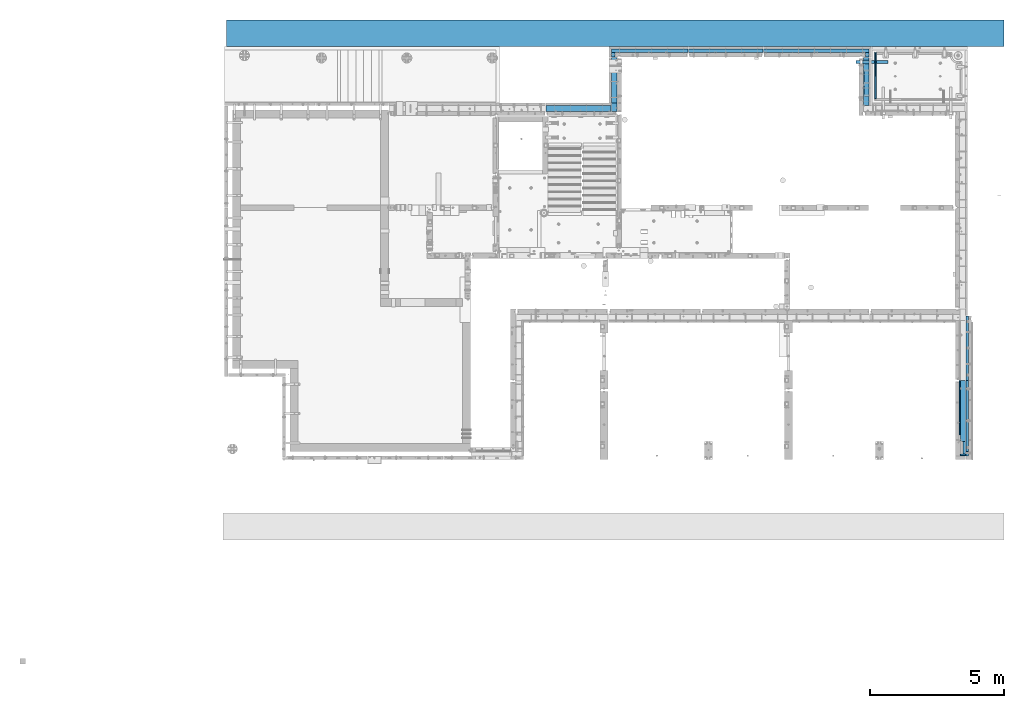
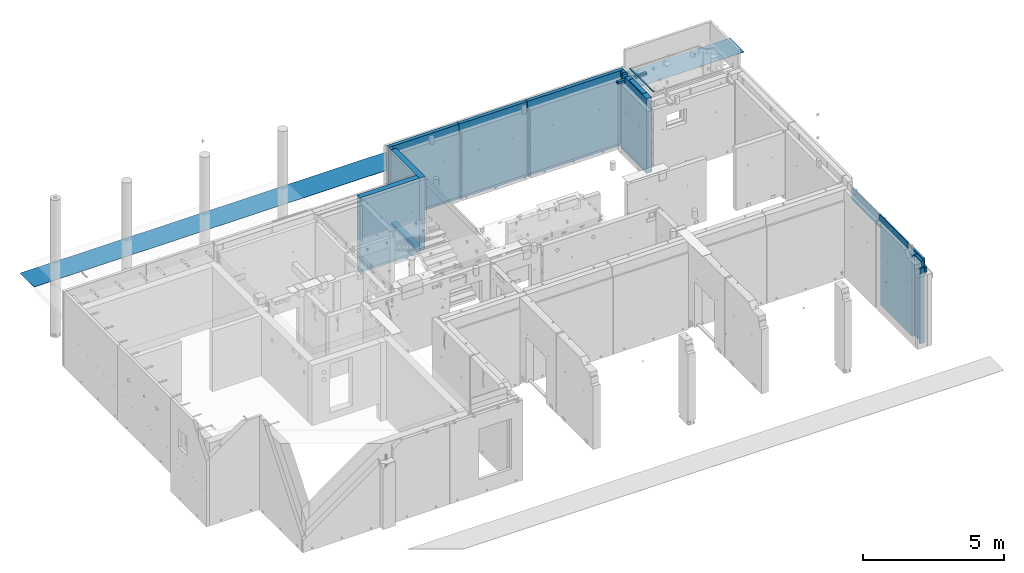
# One storey, part 82 of 264: 24 beams, 22 elements without a shape of their own.
"""IFC2X3 building model written with IfcOpenShell, lengths in millimetres."""

from ifc_helpers import new_model, si_unit, frame, origin_with_axes, place, context, subcontext, project, spatial, faceted_brep, material, type_object, element, aggregate, save


model = new_model("IFC2X3")

# Units and contexts
model_context = context("Model", 3, precision=1e-05, world=origin_with_axes())
body_context = subcontext(model_context, "Body", "Model", "MODEL_VIEW")
ifc_project = project(units=[si_unit("LENGTHUNIT", "METRE", prefix="MILLI"), si_unit("AREAUNIT", "SQUARE_METRE"), si_unit("VOLUMEUNIT", "CUBIC_METRE"), si_unit("MASSUNIT", "GRAM", prefix="KILO"), si_unit("TIMEUNIT", "SECOND"), si_unit("PLANEANGLEUNIT", "RADIAN"), si_unit("SOLIDANGLEUNIT", "STERADIAN"), si_unit("THERMODYNAMICTEMPERATUREUNIT", "DEGREE_CELSIUS"), si_unit("LUMINOUSINTENSITYUNIT", "LUMEN")], contexts=[model_context])

# Site, building, storey
site_placement = place(None, origin_with_axes())
site = spatial("IfcSite", under=ifc_project, at=site_placement, CompositionType="ELEMENT")
building_placement = place(site_placement, origin_with_axes())
building = spatial("IfcBuilding", under=site, at=building_placement, CompositionType="ELEMENT")
storey_placement = place(building_placement, origin_with_axes())
storey = spatial("IfcBuildingStorey", under=building, at=storey_placement, Name="K", CompositionType="ELEMENT", Elevation=0.0)

# Assemblies, beams
assembly_1_placement = place(storey_placement, origin_with_axes())
assembly_1 = element("IfcElementAssembly", 1, at=assembly_1_placement, inside=storey, AssemblyPlace="NOTDEFINED", PredefinedType="REINFORCEMENT_UNIT")
assembly_2_placement = place(assembly_1_placement, origin_with_axes())
assembly_2 = element("IfcElementAssembly", 2, at=assembly_2_placement, AssemblyPlace="NOTDEFINED", PredefinedType="NOTDEFINED")
ifc_material_1 = material(Name="Undefined/350")
beam_type_1 = type_object("IfcBeamType", Name="100X100X5", PredefinedType="NOTDEFINED")
beam_1_placement = place(assembly_2_placement, frame((32380.0034426031, 22424.9998567989, 81555.0), z_axis=(0.0, 0.0, 1.0), x_axis=(-0.999999999752625, 2.22429999942101e-05, 0.0)))
beam_1 = element("IfcBeam", 3, at=beam_1_placement, type_object=beam_type_1, material=ifc_material_1, ObjectType="100X100X5", context=body_context, shape_type="Brep", body=[
    faceted_brep([(1139.17579440585, -49.9744051074349, 6.25), (1139.1757927444, -44.9999999999991, 6.25), (1143.75111029171, -44.9999999999991, 10.8253175473074), (1143.75111195316, -49.9744035792783, 10.8253175473074), (1150.00111029171, -44.9999999999991, 12.5), (1150.00111195316, -49.9744014917787, 12.5), (1156.25111029171, -44.9999999999991, 10.8253175473074), (1156.25111195316, -49.9743994042774, 10.8253175473074), (1160.82642783901, -44.9999999999991, 6.25), (1160.82642950046, -49.9743978761207, 6.25), (1162.50111029171, -44.9999999999991, 0.0), (1162.50111195316, -49.9743973167779, 0.0), (1160.82642783901, -44.9999999999991, -6.25), (1160.82642950046, -49.9743978761207, -6.25), (1156.25111029171, -44.9999999999991, -10.8253175473074), (1156.25111195316, -49.9743994042774, -10.8253175473074), (1150.00111029171, -44.9999999999991, -12.5), (1150.00111195316, -49.9744014917787, -12.5), (1143.75111029171, -44.9999999999991, -10.8253175473074), (1143.75111195316, -49.9744035792783, -10.8253175473074), (1139.1757927444, -44.9999999999991, -6.25), (1139.17579440585, -49.9744051074349, -6.25), (1137.50111029171, -44.9999999999991, 0.0), (1137.50111195316, -49.9744056667778, 0.0), (1139.1757626844, 44.9999999999982, 6.25), (1139.17576100585, 50.0255948914664, 6.25), (1143.75107855316, 50.0255964196231, 10.8253175473074), (1143.75108023171, 44.9999999999982, 10.8253175473074), (1150.00107855316, 50.0255985071226, 12.5), (1150.00108023171, 44.9999999999982, 12.5), (1156.25107855315, 50.0256005946221, 10.8253175473074), (1156.2510802317, 44.9999999999982, 10.8253175473074), (1160.82639610046, 50.0256021227788, 6.25), (1160.82639777901, 44.9999999999982, 6.25), (1162.50107855316, 50.0256026821226, 0.0), (1162.50108023171, 44.9999999999982, 0.0), (1160.82639610046, 50.0256021227788, -6.25), (1160.82639777901, 44.9999999999982, -6.25), (1156.25107855315, 50.0256005946221, -10.8253175473074), (1156.2510802317, 44.9999999999982, -10.8253175473074), (1150.00107855316, 50.0255985071226, -12.5), (1150.00108023171, 44.9999999999982, -12.5), (1143.75107855316, 50.0255964196231, -10.8253175473074), (1143.75108023171, 44.9999999999982, -10.8253175473074), (1139.17576100585, 50.0255948914664, -6.25), (1139.1757626844, 44.9999999999982, -6.25), (1137.50107855316, 50.0255943321226, 0.0), (1137.5010802317, 44.9999999999982, 0.0), (1.81898940354586e-12, -50.0000000000009, -50.0), (1.81898940354586e-12, 49.9999999999991, -50.0), (1200.00449189278, 49.9999999999982, -50.0), (1200.00449189278, -50.0000000000009, -50.0), (1.81898940354586e-12, -50.0000000000009, 50.0), (1200.00449189278, -50.0000000000009, 50.0), (1.81898940354586e-12, 49.9999999999991, 50.0), (1200.00449189278, 49.9999999999982, 50.0), (0.0, 44.9999999999991, 45.0), (1.81898940354586e-12, -45.0000000000009, 45.0), (1.81898940354586e-12, -45.0000000000009, -45.0), (0.0, 44.9999999999991, -45.0), (1200.00449189278, 44.9999999999982, -45.0), (1200.00449189278, 44.9999999999982, 45.0), (1200.00449189278, -45.0000000000009, 45.0), (1200.00449189278, -45.0000000000009, -45.0)], [[[0, 1, 2, 3]], [[3, 2, 4, 5]], [[5, 4, 6, 7]], [[7, 6, 8, 9]], [[9, 8, 10, 11]], [[11, 10, 12, 13]], [[13, 12, 14, 15]], [[15, 14, 16, 17]], [[17, 16, 18, 19]], [[19, 18, 20, 21]], [[21, 20, 22, 23]], [[23, 22, 1, 0]], [[24, 25, 26, 27]], [[27, 26, 28, 29]], [[29, 28, 30, 31]], [[31, 30, 32, 33]], [[33, 32, 34, 35]], [[35, 34, 36, 37]], [[37, 36, 38, 39]], [[39, 38, 40, 41]], [[41, 40, 42, 43]], [[43, 42, 44, 45]], [[45, 44, 46, 47]], [[47, 46, 25, 24]], [[48, 49, 50, 51]], [[52, 48, 51, 53], [15, 17, 19, 21, 23, 0, 3, 5, 7, 9, 11, 13]], [[54, 52, 53, 55]], [[48, 52, 54, 49], [56, 57, 58, 59]], [[56, 59, 60, 61], [39, 41, 43, 45, 47, 24, 27, 29, 31, 33, 35, 37]], [[57, 56, 61, 62]], [[58, 57, 62, 63], [6, 4, 2, 1, 22, 20, 18, 16, 14, 12, 10, 8]], [[59, 58, 63, 60]], [[53, 51, 50, 55], [62, 61, 60, 63]], [[49, 54, 55, 50], [30, 28, 26, 25, 46, 44, 42, 40, 38, 36, 34, 32]]]),
])
aggregate(assembly_2, [beam_1])
ifc_material_2 = material(Name="CONCRETE/Concrete_Undefined")
beam_type_2 = type_object("IfcBeamType", PredefinedType="NOTDEFINED")
beam_2_placement = place(assembly_1_placement, frame((31909.9986098709, 21060.0524822207, 81725.2791116282), z_axis=(7.99999906921644e-09, 0.0107912409985276, 0.999941772863656), x_axis=(7.22999999800065e-07, 0.999941772863395, -0.0107912409985247)))
beam_2 = element("IfcBeam", 4, at=beam_2_placement, type_object=beam_type_2, material=ifc_material_2, context=body_context, shape_type="Brep", body=[
    faceted_brep([(2.5465851649642e-11, 29.9999999999982, -4.99999999998545), (-2.91038304567337e-11, 29.9999999999982, 5.0), (1725.04446838825, 29.9999999999927, 4.99999999998545), (1725.04446838825, 29.9999999999927, -5.00000000001455), (-2.5465851649642e-11, -30.0000000000018, 5.0), (1725.04446838824, -30.0000000000073, 4.99999999998545), (2.72848410531878e-11, -30.0000000000018, -4.99999999998545), (1725.04446838824, -30.0000000000073, -5.0)], [[[0, 1, 2, 3]], [[1, 4, 5, 2]], [[4, 6, 7, 5]], [[6, 0, 3, 7]], [[5, 7, 3, 2]], [[6, 4, 1, 0]]]),
])
aggregate(assembly_1, [assembly_2, beam_2])

# Assembly, beam
assembly_3_placement = place(storey_placement, origin_with_axes())
assembly_3 = element("IfcElementAssembly", 5, at=assembly_3_placement, inside=storey, AssemblyPlace="NOTDEFINED", PredefinedType="REINFORCEMENT_UNIT")
ifc_material_3 = material(Name="CONCRETE/C25/30")
beam_type_3 = type_object("IfcBeamType", PredefinedType="NOTDEFINED")
beam_3_placement = place(assembly_3_placement, frame((31569.9963458483, 22605.0011296565, 78540.0), z_axis=(0.0, 0.0, 1.0), x_axis=(0.0, -1.0, 0.0)))
beam_3 = element("IfcBeam", 6, at=beam_3_placement, type_object=beam_type_3, material=ifc_material_3, context=body_context, shape_type="Brep", body=[
    faceted_brep([(-3.63797880709171e-12, 109.999999999996, -50.0), (-3.63797880709171e-12, 109.999999999996, 50.0), (1800.00126747966, 110.000000000004, 50.0), (1800.00126747966, 110.000000000004, -50.0), (-3.63797880709171e-12, -110.0, 50.0), (1800.00126747966, -110.0, 50.0), (-3.63797880709171e-12, -110.0, -50.0), (1800.00126747966, -110.0, -50.0)], [[[0, 1, 2, 3]], [[1, 4, 5, 2]], [[4, 6, 7, 5]], [[6, 0, 3, 7]], [[5, 7, 3, 2]], [[6, 4, 1, 0]]]),
])

assembly_4_placement = place(storey_placement, origin_with_axes())
assembly_4 = element("IfcElementAssembly", 7, at=assembly_4_placement, inside=storey, AssemblyPlace="NOTDEFINED", PredefinedType="REINFORCEMENT_UNIT")
beam_4_placement = place(assembly_4_placement, frame((22139.9994055291, 20899.9994219008, 78540.0), z_axis=(0.0, 0.0, 1.0), x_axis=(0.0, 1.0, 0.0)))
beam_4 = element("IfcBeam", 8, at=beam_4_placement, type_object=beam_type_3, material=ifc_material_3, context=body_context, shape_type="Brep", body=[
    faceted_brep([(-3.63797880709171e-12, 109.999999999996, -50.0), (-3.63797880709171e-12, 109.999999999996, 50.0), (1705.00057809919, 110.0, 50.0), (1705.00057809919, 110.0, -50.0), (-3.63797880709171e-12, -110.0, 50.0), (1705.00057809919, -110.0, 50.0), (-3.63797880709171e-12, -110.0, -50.0), (1705.00057809919, -110.0, -50.0)], [[[0, 1, 2, 3]], [[1, 4, 5, 2]], [[4, 6, 7, 5]], [[6, 0, 3, 7]], [[5, 7, 3, 2]], [[6, 4, 1, 0]]]),
])

assembly_5_placement = place(storey_placement, origin_with_axes())
assembly_5 = element("IfcElementAssembly", 9, at=assembly_5_placement, inside=storey, AssemblyPlace="NOTDEFINED", PredefinedType="REINFORCEMENT_UNIT")
beam_5_placement = place(assembly_5_placement, frame((19590.0015145227, 20690.0000000017, 78540.0), z_axis=(0.0, 0.0, 1.0), x_axis=(1.0, 0.0, 0.0)))
beam_5 = element("IfcBeam", 10, at=beam_5_placement, type_object=beam_type_3, material=ifc_material_3, context=body_context, shape_type="Brep", body=[
    faceted_brep([(-3.63797880709171e-12, 109.999999999996, -50.0), (-3.63797880709171e-12, 109.999999999996, 50.0), (2434.99930971011, 110.000000000004, 50.0), (2434.99930971011, 110.000000000004, -50.0), (-3.63797880709171e-12, -110.0, 50.0), (2434.99930971011, -109.999999999996, 50.0), (-3.63797880709171e-12, -110.0, -50.0), (2434.99930971011, -109.999999999996, -50.0)], [[[0, 1, 2, 3]], [[1, 4, 5, 2]], [[4, 6, 7, 5]], [[6, 0, 3, 7]], [[5, 7, 3, 2]], [[6, 4, 1, 0]]]),
])

# Beam
ifc_material_4 = material(Name="TIMBER")
beam_type_4 = type_object("IfcBeamType", PredefinedType="NOTDEFINED")
beam_6_placement = place(assembly_3_placement, frame((31589.9951872276, 22135.0000381475, 81715.0), z_axis=(0.0, 0.0, 1.0), x_axis=(0.0, -1.0, 0.0)))
beam_6 = element("IfcBeam", 11, at=beam_6_placement, type_object=beam_type_4, material=ifc_material_4, context=body_context, shape_type="Brep", body=[
    faceted_brep([(0.0, 90.0, -25.0), (0.0, 90.0, 25.0), (989.99983857082, 90.0, 25.0), (989.99983857082, 90.0, -25.0), (0.0, -90.0, 25.0), (989.99983857082, -90.0, 25.0), (0.0, -90.0, -25.0), (989.99983857082, -90.0, -25.0)], [[[0, 1, 2, 3]], [[1, 4, 5, 2]], [[4, 6, 7, 5]], [[6, 0, 3, 7]], [[5, 7, 3, 2]], [[6, 4, 1, 0]]]),
])

# Assemblies, beams
assembly_6_placement = place(storey_placement, origin_with_axes())
assembly_6 = element("IfcElementAssembly", 12, at=assembly_6_placement, inside=storey, AssemblyPlace="NOTDEFINED", PredefinedType="REINFORCEMENT_UNIT")
assembly_7_placement = place(assembly_6_placement, origin_with_axes())
assembly_7 = element("IfcElementAssembly", 13, at=assembly_7_placement, Name="Steel Assembly", AssemblyPlace="NOTDEFINED", PredefinedType="NOTDEFINED")
ifc_material_5 = material(Name="SPU")
beam_type_5 = type_object("IfcBeamType", PredefinedType="NOTDEFINED")
beam_7_placement = place(assembly_7_placement, frame((35240.0024573137, 8230.00189658477, 79557.5), z_axis=(0.0, 0.0, 1.0), x_axis=(0.0, -1.0, 0.0)))
beam_7 = element("IfcBeam", 14, at=beam_7_placement, type_object=beam_type_5, material=ifc_material_5, context=body_context, shape_type="Brep", body=[
    faceted_brep([(0.0, 50.0, -1757.5), (0.0, 50.0, 1757.5), (480.0, 50.0, 1757.5), (480.0, 50.0, -1757.5), (0.0, -50.0, 1757.5), (480.0, -50.0, 1757.5), (0.0, -50.0, -1757.5), (480.0, -50.0, -1757.5)], [[[0, 1, 2, 3]], [[1, 4, 5, 2]], [[4, 6, 7, 5]], [[6, 0, 3, 7]], [[5, 7, 3, 2]], [[6, 4, 1, 0]]]),
])
aggregate(assembly_7, [beam_7])
assembly_8_placement = place(assembly_6_placement, origin_with_axes())
assembly_8 = element("IfcElementAssembly", 15, at=assembly_8_placement, Name="Steel Assembly", AssemblyPlace="NOTDEFINED", PredefinedType="NOTDEFINED")
beam_type_6 = type_object("IfcBeamType", PredefinedType="NOTDEFINED")
beam_8_placement = place(assembly_8_placement, frame((35290.0024573137, 7720.00189658477, 79425.0), z_axis=(0.0, 0.0, 1.0), x_axis=(-1.0, 3.00000001838171e-08, 0.0)))
beam_8 = element("IfcBeam", 16, at=beam_8_placement, type_object=beam_type_6, material=ifc_material_5, context=body_context, shape_type="Brep", body=[
    faceted_brep([(0.0, 30.0, -1625.0), (0.0, 30.0, 1625.0), (200.0, 30.0, 1625.0), (200.0, 30.0, -1625.0), (0.0, -30.0, 1625.0), (200.0, -30.0, 1625.0), (0.0, -30.0, -1625.0), (200.0, -30.0, -1625.0)], [[[0, 1, 2, 3]], [[1, 4, 5, 2]], [[4, 6, 7, 5]], [[6, 0, 3, 7]], [[5, 7, 3, 2]], [[6, 4, 1, 0]]]),
])
aggregate(assembly_8, [beam_8])
ifc_material_6 = material(Name="CONCRETE/C30/37")
beam_type_7 = type_object("IfcBeamType", Name="270X40", PredefinedType="NOTDEFINED")
beam_9_placement = place(assembly_6_placement, frame((35070.0024573138, 10500.0018965848, 81605.0), z_axis=(0.0, 0.0, 1.0), x_axis=(0.0, -1.0, 0.0)))
beam_9 = element("IfcBeam", 17, at=beam_9_placement, type_object=beam_type_7, material=ifc_material_6, ObjectType="270X40", context=body_context, shape_type="Brep", body=[
    faceted_brep([(0.0, 20.0, -135.0), (0.0, 20.0, 135.0), (2040.00000000001, 20.0, 135.0), (2040.00000000001, 20.0, -135.0), (0.0, -20.0, 135.0), (2040.00000000001, -20.0, 135.0), (0.0, -20.0, -135.0), (2040.00000000001, -20.0, -135.0)], [[[0, 1, 2, 3]], [[1, 4, 5, 2]], [[4, 6, 7, 5]], [[6, 0, 3, 7]], [[5, 7, 3, 2]], [[6, 4, 1, 0]]]),
])

# Assembly, beam
assembly_9_placement = place(storey_placement, origin_with_axes())
assembly_9 = element("IfcElementAssembly", 18, at=assembly_9_placement, inside=storey, AssemblyPlace="NOTDEFINED", PredefinedType="REINFORCEMENT_UNIT")
ifc_material_7 = material(Name="CONCRETE/C35/45")
beam_type_8 = type_object("IfcBeamType", Name="500X80", PredefinedType="NOTDEFINED")
beam_10_placement = place(assembly_9_placement, frame((35350.0000014901, 7689.99999999999, 81065.0030770672), z_axis=(0.0, 0.0, 1.0), x_axis=(0.0, 1.0, 0.0)))
beam_10 = element("IfcBeam", 19, at=beam_10_placement, type_object=beam_type_8, material=ifc_material_7, ObjectType="500X80", context=body_context, shape_type="Brep", body=[
    faceted_brep([(160.001896584774, -40.0, -15.0030770672456), (160.001896584774, 40.0, -15.0030770672456), (0.0, 40.0, -15.0030770672456), (0.0, -40.0, -15.0030770672456), (160.001896584774, -40.0, 250.0), (160.001896584774, 40.0, 250.0), (0.0, -40.0, -250.0), (0.0, 40.0, -250.0), (2809.99965490548, 40.0, -250.0), (2809.99965490548, -40.0, -250.0), (2809.99965490548, -40.0, 250.0), (2809.99965490548, 40.0, 250.0)], [[[0, 1, 2, 3]], [[4, 5, 1, 0]], [[6, 7, 8, 9]], [[10, 9, 8, 11]], [[3, 6, 9, 10, 4, 0]], [[7, 6, 3, 2]], [[11, 8, 7, 2, 1, 5]], [[10, 11, 5, 4]]]),
])
aggregate(assembly_9, [beam_10])

assembly_10_placement = place(storey_placement, origin_with_axes())
assembly_10 = element("IfcElementAssembly", 20, at=assembly_10_placement, inside=storey, AssemblyPlace="NOTDEFINED", PredefinedType="REINFORCEMENT_UNIT")
beam_11_placement = place(assembly_10_placement, frame((35350.0000014901, 10515.0, 81065.0030770672), z_axis=(0.0, 0.0, 1.0), x_axis=(0.0, 1.0, 0.0)))
beam_11 = element("IfcBeam", 21, at=beam_11_placement, type_object=beam_type_8, material=ifc_material_7, ObjectType="500X80", context=body_context, shape_type="Brep", body=[
    faceted_brep([(0.0, 40.0, -250.0), (0.0, 40.0, 250.0), (2404.98965490548, 40.0, 250.0), (2404.98965490548, 40.0, -250.0), (0.0, -40.0, 250.0), (2404.98965490548, -40.0, 250.0), (0.0, -40.0, -250.0), (2404.98965490548, -40.0, -250.0)], [[[0, 1, 2, 3]], [[1, 4, 5, 2]], [[4, 6, 7, 5]], [[6, 0, 3, 7]], [[5, 7, 3, 2]], [[6, 4, 1, 0]]]),
])
aggregate(assembly_10, [beam_11])

# Assemblies, beam
assembly_11_placement = place(storey_placement, origin_with_axes())
assembly_11 = element("IfcElementAssembly", 22, at=assembly_11_placement, inside=storey, AssemblyPlace="NOTDEFINED", PredefinedType="REINFORCEMENT_UNIT")
assembly_12_placement = place(assembly_11_placement, origin_with_axes())
assembly_12 = element("IfcElementAssembly", 23, at=assembly_12_placement, Name="Steel Assembly", AssemblyPlace="NOTDEFINED", PredefinedType="NOTDEFINED")
beam_type_9 = type_object("IfcBeamType", PredefinedType="NOTDEFINED")
beam_12_placement = place(assembly_12_placement, frame((24919.9998937355, 22850.0000000001, 80165.0), z_axis=(0.0, 0.0, 1.0), x_axis=(1.0, 0.0, 0.0)))
beam_12 = element("IfcBeam", 24, at=beam_12_placement, type_object=beam_type_9, material=ifc_material_5, context=body_context, shape_type="Brep", body=[
    faceted_brep([(0.0, 70.0, -1575.0), (0.0, 70.0, 1575.0), (2784.99635398067, 70.0, 1575.0), (2784.99635398067, 70.0, -1575.0), (3.63797880709171e-12, -70.0, 1575.0), (2784.99635398067, -70.0, 1575.0), (3.63797880709171e-12, -70.0, -1575.0), (2784.99635398067, -70.0, -1575.0)], [[[0, 1, 2, 3]], [[1, 4, 5, 2]], [[4, 6, 7, 5]], [[6, 0, 3, 7]], [[5, 7, 3, 2]], [[6, 4, 1, 0]]]),
])
aggregate(assembly_12, [beam_12])

assembly_13_placement = place(storey_placement, origin_with_axes())
assembly_13 = element("IfcElementAssembly", 25, at=assembly_13_placement, inside=storey, AssemblyPlace="NOTDEFINED", PredefinedType="REINFORCEMENT_UNIT")
assembly_14_placement = place(assembly_13_placement, origin_with_axes())
assembly_14 = element("IfcElementAssembly", 26, at=assembly_14_placement, Name="Steel Assembly", AssemblyPlace="NOTDEFINED", PredefinedType="NOTDEFINED")
beam_13_placement = place(assembly_14_placement, frame((22099.9994055291, 22780.0, 80165.0), z_axis=(0.0, 0.0, 1.0), x_axis=(0.0, -1.0, 0.0)))
beam_13 = element("IfcBeam", 27, at=beam_13_placement, type_object=beam_type_9, material=ifc_material_5, context=body_context, shape_type="Brep", body=[
    faceted_brep([(0.0, 70.0, -1575.0), (0.0, 70.0, 1575.0), (160.0, 70.0, 1575.0), (160.0, 70.0, -1575.0), (3.63797880709171e-12, -70.0, 1575.0), (160.0, -70.0, 1575.0), (3.63797880709171e-12, -70.0, -1575.0), (160.0, -70.0, -1575.0)], [[[0, 1, 2, 3]], [[1, 4, 5, 2]], [[4, 6, 7, 5]], [[6, 0, 3, 7]], [[5, 7, 3, 2]], [[6, 4, 1, 0]]]),
])
aggregate(assembly_14, [beam_13])

# Assemblies, beams
assembly_15_placement = place(storey_placement, origin_with_axes())
assembly_15 = element("IfcElementAssembly", 28, at=assembly_15_placement, inside=storey, AssemblyPlace="NOTDEFINED", PredefinedType="REINFORCEMENT_UNIT")
assembly_16_placement = place(assembly_15_placement, origin_with_axes())
assembly_16 = element("IfcElementAssembly", 29, at=assembly_16_placement, Name="Steel Assembly", AssemblyPlace="NOTDEFINED", PredefinedType="NOTDEFINED")
beam_14_placement = place(assembly_16_placement, frame((31609.996303048, 22780.0012355063, 80165.0), z_axis=(0.0, 0.0, 1.0), x_axis=(0.0, -1.0, 0.0)))
beam_14 = element("IfcBeam", 30, at=beam_14_placement, type_object=beam_type_9, material=ifc_material_5, context=body_context, shape_type="Brep", body=[
    faceted_brep([(0.0, 70.0, -1575.0), (0.0, 70.0, 1575.0), (160.0, 70.0, 1575.0), (160.0, 70.0, -1575.0), (3.63797880709171e-12, -70.0, 1575.0), (160.0, -70.0, 1575.0), (3.63797880709171e-12, -70.0, -1575.0), (160.0, -70.0, -1575.0)], [[[0, 1, 2, 3]], [[1, 4, 5, 2]], [[4, 6, 7, 5]], [[6, 0, 3, 7]], [[5, 7, 3, 2]], [[6, 4, 1, 0]]]),
])
aggregate(assembly_16, [beam_14])
assembly_17_placement = place(assembly_15_placement, origin_with_axes())
assembly_17 = element("IfcElementAssembly", 31, at=assembly_17_placement, Name="Steel Assembly", AssemblyPlace="NOTDEFINED", PredefinedType="NOTDEFINED")
beam_15_placement = place(assembly_17_placement, frame((27719.9999397544, 22850.0000023817, 80165.0), z_axis=(0.0, 0.0, 1.0), x_axis=(1.0, 0.0, 0.0)))
beam_15 = element("IfcBeam", 32, at=beam_15_placement, type_object=beam_type_9, material=ifc_material_5, context=body_context, shape_type="Brep", body=[
    faceted_brep([(0.0, 70.0, -1575.0), (0.0, 70.0, 1575.0), (3959.99634110523, 70.0000000000036, 1575.0), (3959.99634110523, 70.0000000000036, -1575.0), (3.63797880709171e-12, -70.0, 1575.0), (3959.99634110523, -69.9999999999927, 1575.0), (3.63797880709171e-12, -70.0, -1575.0), (3959.99634110523, -69.9999999999927, -1575.0)], [[[0, 1, 2, 3]], [[1, 4, 5, 2]], [[4, 6, 7, 5]], [[6, 0, 3, 7]], [[5, 7, 3, 2]], [[6, 4, 1, 0]]]),
])
aggregate(assembly_17, [beam_15])

# Beam
beam_16_placement = place(assembly_13_placement, frame((22029.9994055291, 22850.0, 80165.0), z_axis=(0.0, 0.0, 1.0), x_axis=(1.0, 0.0, 0.0)))
beam_16 = element("IfcBeam", 33, at=beam_16_placement, type_object=beam_type_9, material=ifc_material_5, context=body_context, shape_type="Brep", body=[
    faceted_brep([(0.0, 70.0, -1575.0), (0.0, 70.0, 1575.0), (2875.00056592515, 70.0, 1575.0), (2875.00056592515, 70.0, -1575.0), (3.63797880709171e-12, -70.0, 1575.0), (2875.00056592515, -70.0, 1575.0), (3.63797880709171e-12, -70.0, -1575.0), (2875.00056592515, -70.0, -1575.0)], [[[0, 1, 2, 3]], [[1, 4, 5, 2]], [[4, 6, 7, 5]], [[6, 0, 3, 7]], [[5, 7, 3, 2]], [[6, 4, 1, 0]]]),
])

beam_type_10 = type_object("IfcBeamType", PredefinedType="NOTDEFINED")
beam_17_placement = place(assembly_11_placement, frame((24919.9998937355, 22850.0000000001, 78540.0), z_axis=(0.0, 0.0, 1.0), x_axis=(1.0, 0.0, 0.0)))
beam_17 = element("IfcBeam", 34, at=beam_17_placement, type_object=beam_type_10, material=ifc_material_3, context=body_context, shape_type="Brep", body=[
    faceted_brep([(0.0, 70.0, -50.0), (0.0, 70.0, 50.0), (2784.99635398067, 70.0, 50.0), (2784.99635398067, 70.0, -50.0), (3.63797880709171e-12, -70.0, 50.0), (2784.99635398067, -70.0, 50.0), (3.63797880709171e-12, -70.0, -50.0), (2784.99635398067, -70.0, -50.0)], [[[0, 1, 2, 3]], [[1, 4, 5, 2]], [[4, 6, 7, 5]], [[6, 0, 3, 7]], [[5, 7, 3, 2]], [[6, 4, 1, 0]]]),
])

aggregate(assembly_11, [assembly_12, beam_17])

beam_18_placement = place(assembly_15_placement, frame((27719.9999397544, 22850.0000023817, 78540.0), z_axis=(0.0, 0.0, 1.0), x_axis=(1.0, 0.0, 0.0)))
beam_18 = element("IfcBeam", 35, at=beam_18_placement, type_object=beam_type_10, material=ifc_material_3, context=body_context, shape_type="Brep", body=[
    faceted_brep([(0.0, 70.0, -50.0), (0.0, 70.0, 50.0), (3959.99634110523, 70.0000000000036, 50.0), (3959.99634110523, 70.0000000000036, -50.0), (3.63797880709171e-12, -70.0, 50.0), (3959.99634110523, -69.9999999999927, 50.0), (3.63797880709171e-12, -70.0, -50.0), (3959.99634110523, -69.9999999999927, -50.0)], [[[0, 1, 2, 3]], [[1, 4, 5, 2]], [[4, 6, 7, 5]], [[6, 0, 3, 7]], [[5, 7, 3, 2]], [[6, 4, 1, 0]]]),
])

aggregate(assembly_15, [assembly_16, beam_18, assembly_17])

beam_19_placement = place(assembly_13_placement, frame((22029.9994055291, 22850.0, 78540.0), z_axis=(0.0, 0.0, 1.0), x_axis=(1.0, 0.0, 0.0)))
beam_19 = element("IfcBeam", 36, at=beam_19_placement, type_object=beam_type_10, material=ifc_material_3, context=body_context, shape_type="Brep", body=[
    faceted_brep([(0.0, 70.0, -50.0), (0.0, 70.0, 50.0), (2875.00056592515, 70.0, 50.0), (2875.00056592515, 70.0, -50.0), (3.63797880709171e-12, -70.0, 50.0), (2875.00056592515, -70.0, 50.0), (3.63797880709171e-12, -70.0, -50.0), (2875.00056592515, -70.0, -50.0)], [[[0, 1, 2, 3]], [[1, 4, 5, 2]], [[4, 6, 7, 5]], [[6, 0, 3, 7]], [[5, 7, 3, 2]], [[6, 4, 1, 0]]]),
])

aggregate(assembly_13, [assembly_14, beam_19, beam_16])

# Assembly, beam
assembly_18_placement = place(storey_placement, origin_with_axes())
assembly_18 = element("IfcElementAssembly", 37, at=assembly_18_placement, inside=storey, Name="Steel Assembly", AssemblyPlace="NOTDEFINED", PredefinedType="NOTDEFINED")
ifc_material_8 = material()
beam_type_11 = type_object("IfcBeamType", PredefinedType="NOTDEFINED")
beam_20_placement = place(assembly_18_placement, frame((7619.99647968724, 23500.0002194537, 80592.5), z_axis=(0.0, 1.0, 0.0), x_axis=(1.0, 0.0, 0.0)))
beam_20 = element("IfcBeam", 38, at=beam_20_placement, type_object=beam_type_11, material=ifc_material_8, context=body_context, shape_type="Brep", body=[
    faceted_brep([(0.0, 7.5, -500.0), (0.0, 7.5, 500.0), (29105.0, 7.5, 500.0), (29105.0, 7.5, -500.0), (0.0, -7.5, 500.0), (29105.0, -7.5, 500.0), (0.0, -7.5, -500.0), (29105.0, -7.5, -500.0)], [[[0, 1, 2, 3]], [[1, 4, 5, 2]], [[4, 6, 7, 5]], [[6, 0, 3, 7]], [[5, 7, 3, 2]], [[6, 4, 1, 0]]]),
])
aggregate(assembly_18, [beam_20])

# Assembly
assembly_19_placement = place(assembly_6_placement, origin_with_axes())
assembly_19 = element("IfcElementAssembly", 39, at=assembly_19_placement, Name="Steel Assembly", AssemblyPlace="NOTDEFINED", PredefinedType="NOTDEFINED")

aggregate(assembly_6, [assembly_7, assembly_8, beam_9, assembly_19])

# Beam
ifc_material_9 = material(Name="EPS100")
beam_type_12 = type_object("IfcBeamType", PredefinedType="NOTDEFINED")
beam_21_placement = place(assembly_19_placement, frame((35190.0024573137, 10500.0018965848, 79557.5), z_axis=(0.0, 0.0, 1.0), x_axis=(0.0, -1.0, 0.0)))
beam_21 = element("IfcBeam", 40, at=beam_21_placement, type_object=beam_type_12, material=ifc_material_9, context=body_context, shape_type="Brep", body=[
    faceted_brep([(0.0, 100.0, -1757.5), (0.0, 100.0, 1757.5), (2270.0, 100.0, 1757.5), (2270.0, 100.0, -1757.5), (0.0, -100.0, 1757.5), (2270.0, -100.0, 1757.5), (0.0, -100.0, -1757.5), (2270.0, -100.0, -1757.5)], [[[0, 1, 2, 3]], [[1, 4, 5, 2]], [[4, 6, 7, 5]], [[6, 0, 3, 7]], [[5, 7, 3, 2]], [[6, 4, 1, 0]]]),
])

aggregate(assembly_19, [beam_21])

# Assembly
assembly_20_placement = place(assembly_3_placement, origin_with_axes())
assembly_20 = element("IfcElementAssembly", 41, at=assembly_20_placement, Name="Steel Assembly", AssemblyPlace="NOTDEFINED", PredefinedType="NOTDEFINED")

aggregate(assembly_3, [beam_6, beam_3, assembly_20])

# Beam
beam_type_13 = type_object("IfcBeamType", PredefinedType="NOTDEFINED")
beam_22_placement = place(assembly_20_placement, frame((31569.9963458483, 22605.0011296565, 80165.0), z_axis=(0.0, 0.0, 1.0), x_axis=(0.0, -1.0, 0.0)))
beam_22 = element("IfcBeam", 42, at=beam_22_placement, type_object=beam_type_13, material=ifc_material_9, context=body_context, shape_type="Brep", body=[
    faceted_brep([(254.980814402188, 110.000000000004, 1575.0), (254.980814402188, 110.000000000004, 1305.0), (254.980853342186, -110.000000000004, 1305.0), (254.980853342186, -110.000000000004, 1575.0), (104.98078388461, 110.000000000004, 1305.0), (104.980822824611, -110.000000000004, 1305.0), (104.98078388461, 110.000000000004, 1575.0), (104.980822824611, -110.000000000004, 1575.0), (1800.00126747966, -110.0, 1575.0), (1800.00126747966, -110.0, -1575.0), (1800.00126747966, 110.000000000004, -1575.0), (1800.00126747966, 110.000000000004, 1575.0), (-7.27595761418343e-12, -110.0, -1575.0), (-7.27595761418343e-12, 110.000000000007, -1575.0), (-7.27595761418343e-12, -110.0, 1575.0), (-7.27595761418343e-12, 110.000000000007, 1575.0)], [[[0, 1, 2, 3]], [[4, 5, 2, 1]], [[6, 7, 5, 4]], [[8, 9, 10, 11]], [[12, 13, 10, 9]], [[12, 14, 15, 13]], [[1, 0, 11, 10, 13, 15, 6, 4]], [[8, 11, 0, 3]], [[14, 12, 9, 8, 3, 2, 5, 7]], [[15, 14, 7, 6]]]),
])

aggregate(assembly_20, [beam_22])

# Assembly
assembly_21_placement = place(assembly_4_placement, origin_with_axes())
assembly_21 = element("IfcElementAssembly", 43, at=assembly_21_placement, Name="Steel Assembly", AssemblyPlace="NOTDEFINED", PredefinedType="NOTDEFINED")

aggregate(assembly_4, [beam_4, assembly_21])

# Beam
beam_23_placement = place(assembly_21_placement, frame((22139.9994055291, 20584.9994219008, 80165.0), z_axis=(0.0, 0.0, 1.0), x_axis=(0.0, 1.0, 0.0)))
beam_23 = element("IfcBeam", 44, at=beam_23_placement, type_object=beam_type_13, material=ifc_material_9, context=body_context, shape_type="Brep", body=[
    faceted_brep([(1931.59399847138, -110.0, -790.881904510257), (1931.59399847138, 110.0, -790.881904510257), (1921.60395622092, 110.0, -815.0), (1921.60395622092, -110.0, -815.0), (1905.71209396113, 110.0, -835.710678118659), (1905.71209396113, -110.0, -835.710678118659), (1885.00141584247, 110.0, -851.602540378444), (1885.00141584247, -110.0, -851.602540378444), (1860.88332035273, 110.0, -861.592582628902), (1860.88332035273, -110.0, -861.592582628902), (1835.00141584247, 110.0, -865.0), (1835.00141584247, -110.0, -865.0), (1809.11951133222, 110.0, -861.592582628902), (1809.11951133222, -110.0, -861.592582628902), (1785.00141584247, 110.0, -851.602540378444), (1785.00141584247, -110.0, -851.602540378444), (1764.29073772382, 110.0, -835.710678118659), (1764.29073772382, -110.0, -835.710678118659), (1748.39887546403, 110.0, -815.0), (1748.39887546403, -110.0, -815.0), (1738.40883321357, 110.0, -790.881904510257), (1738.40883321357, -110.0, -790.881904510257), (1735.00141584247, 110.0, -765.0), (1735.00141584247, -110.0, -765.0), (1738.40883321357, 110.0, -739.118095489743), (1738.40883321357, -110.0, -739.118095489743), (1748.39887546403, 110.0, -715.0), (1748.39887546403, -110.0, -715.0), (1764.29073772382, 110.0, -694.289321881341), (1764.29073772382, -110.0, -694.289321881341), (1785.00141584247, 110.0, -678.397459621556), (1785.00141584247, -110.0, -678.397459621556), (1809.11951133222, 110.0, -668.407417371098), (1809.11951133222, -110.0, -668.407417371098), (1835.00141584247, 110.0, -665.0), (1835.00141584247, -110.0, -665.0), (1860.88332035273, 110.0, -668.407417371098), (1860.88332035273, -110.0, -668.407417371098), (1885.00141584247, 110.0, -678.397459621556), (1885.00141584247, -110.0, -678.397459621556), (1905.71209396113, 110.0, -694.289321881341), (1905.71209396113, -110.0, -694.289321881341), (1921.60395622092, 110.0, -715.0), (1921.60395622092, -110.0, -715.0), (1931.59399847138, 110.0, -739.118095489743), (1931.59399847138, -110.0, -739.118095489743), (1935.00141584247, 110.0, -765.0), (1935.00141584247, -110.0, -765.0), (-7.27595761418343e-12, 110.000000000007, 1575.0), (-7.27595761418343e-12, -110.0, 1575.0), (2020.00057809919, -110.0, 1575.0), (2020.00057809919, 110.0, 1575.0), (-7.27595761418343e-12, -110.0, -1575.0), (-7.27595761418343e-12, 110.000000000007, -1575.0), (2020.00057809919, 110.0, -1575.0), (2020.00057809919, -110.0, -1575.0), (1672.62099845137, -110.0, -819.235467389692), (1657.72882527207, -110.0, -842.936225232348), (1637.93611519591, -110.0, -862.728935308507), (1614.23535735326, -110.0, -877.621108487801), (1587.81500670811, -110.0, -886.865989022728), (1559.99988996357, -110.0, -890.0), (1532.18477321903, -110.0, -886.865989022728), (1505.76442257387, -110.0, -877.621108487801), (1482.06366473123, -110.0, -862.728935308507), (1462.27095465507, -110.0, -842.936225232348), (1447.37878147577, -110.0, -819.235467389692), (1438.13390094084, -110.0, -792.815116744532), (1434.99988996357, -110.0, -765.0), (1438.13390094084, -110.0, -737.184883255468), (1447.37878147577, -110.0, -710.764532610308), (1462.27095465507, -110.0, -687.063774767652), (1482.06366473123, -110.0, -667.271064691493), (1505.76442257387, -110.0, -652.378891512199), (1532.18477321903, -110.0, -643.134010977272), (1559.99988996357, -110.0, -640.0), (1587.81500670811, -110.0, -643.134010977272), (1614.23535735326, -110.0, -652.378891512199), (1637.93611519591, -110.0, -667.271064691493), (1657.72882527207, -110.0, -687.063774767652), (1672.62099845137, -110.0, -710.764532610308), (1681.8658789863, -110.0, -737.184883255468), (1684.99988996357, -110.0, -765.0), (1681.8658789863, -110.0, -792.815116744532), (1672.62099845137, 110.0, -710.764532610308), (1681.8658789863, 110.0, -737.184883255468), (1657.72882527207, 110.0, -687.063774767652), (1637.93611519591, 110.0, -667.271064691493), (1614.23535735326, 110.0, -652.378891512199), (1587.81500670811, 110.0, -643.134010977272), (1559.99988996357, 110.0, -640.0), (1532.18477321903, 110.0, -643.134010977272), (1505.76442257387, 110.0, -652.378891512199), (1482.06366473123, 110.0, -667.271064691493), (1462.27095465507, 110.0, -687.063774767652), (1447.37878147577, 110.0, -710.764532610308), (1438.13390094084, 110.0, -737.184883255468), (1434.99988996357, 110.0, -765.0), (1438.13390094084, 110.0, -792.815116744532), (1447.37878147577, 110.0, -819.235467389692), (1462.27095465507, 110.0, -842.936225232348), (1482.06366473123, 110.0, -862.728935308507), (1505.76442257387, 110.0, -877.621108487801), (1532.18477321903, 110.0, -886.865989022728), (1559.99988996357, 110.0, -890.0), (1587.81500670811, 110.0, -886.865989022728), (1614.23535735326, 110.0, -877.621108487801), (1637.93611519591, 110.0, -862.728935308507), (1657.72882527207, 110.0, -842.936225232348), (1672.62099845137, 110.0, -819.235467389692), (1681.8658789863, 110.0, -792.815116744532), (1684.99988996357, 110.0, -765.0)], [[[0, 1, 2, 3]], [[3, 2, 4, 5]], [[5, 4, 6, 7]], [[7, 6, 8, 9]], [[9, 8, 10, 11]], [[11, 10, 12, 13]], [[13, 12, 14, 15]], [[15, 14, 16, 17]], [[17, 16, 18, 19]], [[19, 18, 20, 21]], [[21, 20, 22, 23]], [[23, 22, 24, 25]], [[25, 24, 26, 27]], [[27, 26, 28, 29]], [[29, 28, 30, 31]], [[31, 30, 32, 33]], [[33, 32, 34, 35]], [[35, 34, 36, 37]], [[37, 36, 38, 39]], [[39, 38, 40, 41]], [[41, 40, 42, 43]], [[43, 42, 44, 45]], [[45, 44, 46, 47]], [[47, 46, 1, 0]], [[48, 49, 50, 51]], [[52, 49, 48, 53]], [[52, 53, 54, 55]], [[50, 55, 54, 51]], [[49, 52, 55, 50], [3, 5, 7, 9, 11, 13, 15, 17, 19, 21, 23, 25, 27, 29, 31, 33, 35, 37, 39, 41, 43, 45, 47, 0], [56, 57, 58, 59, 60, 61, 62, 63, 64, 65, 66, 67, 68, 69, 70, 71, 72, 73, 74, 75, 76, 77, 78, 79, 80, 81, 82, 83]], [[80, 84, 85, 81]], [[79, 86, 84, 80]], [[78, 87, 86, 79]], [[77, 88, 87, 78]], [[76, 89, 88, 77]], [[75, 90, 89, 76]], [[74, 91, 90, 75]], [[73, 92, 91, 74]], [[72, 93, 92, 73]], [[71, 94, 93, 72]], [[70, 95, 94, 71]], [[69, 96, 95, 70]], [[68, 97, 96, 69]], [[67, 98, 97, 68]], [[66, 99, 98, 67]], [[65, 100, 99, 66]], [[64, 101, 100, 65]], [[63, 102, 101, 64]], [[62, 103, 102, 63]], [[61, 104, 103, 62]], [[60, 105, 104, 61]], [[59, 106, 105, 60]], [[58, 107, 106, 59]], [[57, 108, 107, 58]], [[56, 109, 108, 57]], [[83, 110, 109, 56]], [[82, 111, 110, 83]], [[81, 85, 111, 82]], [[53, 48, 51, 54], [42, 40, 38, 36, 34, 32, 30, 28, 26, 24, 22, 20, 18, 16, 14, 12, 10, 8, 6, 4, 2, 1, 46, 44], [84, 86, 87, 88, 89, 90, 91, 92, 93, 94, 95, 96, 97, 98, 99, 100, 101, 102, 103, 104, 105, 106, 107, 108, 109, 110, 111, 85]]]),
])

aggregate(assembly_21, [beam_23])

# Assembly
assembly_22_placement = place(assembly_5_placement, origin_with_axes())
assembly_22 = element("IfcElementAssembly", 45, at=assembly_22_placement, Name="Steel Assembly", AssemblyPlace="NOTDEFINED", PredefinedType="NOTDEFINED")

aggregate(assembly_5, [assembly_22, beam_5])

# Beam
beam_24_placement = place(assembly_22_placement, frame((19590.001514522, 20690.0000000017, 80165.0), z_axis=(0.0, 0.0, 1.0), x_axis=(1.0, 0.0, 0.0)))
beam_24 = element("IfcBeam", 46, at=beam_24_placement, type_object=beam_type_13, material=ifc_material_9, context=body_context, shape_type="Brep", body=[
    faceted_brep([(-7.27595761418343e-12, 110.000000000007, -1575.0), (-7.27595761418343e-12, 110.000000000007, 1575.0), (2434.99930971114, 110.0, 1575.0), (2434.99930971114, 110.0, -1575.0), (-7.27595761418343e-12, -110.0, 1575.0), (2434.99930971115, -110.0, 1575.0), (-7.27595761418343e-12, -110.0, -1575.0), (2434.99930971115, -110.0, -1575.0)], [[[0, 1, 2, 3]], [[1, 4, 5, 2]], [[4, 6, 7, 5]], [[6, 0, 3, 7]], [[5, 7, 3, 2]], [[6, 4, 1, 0]]]),
])

aggregate(assembly_22, [beam_24])

save(model, "model.ifc")
